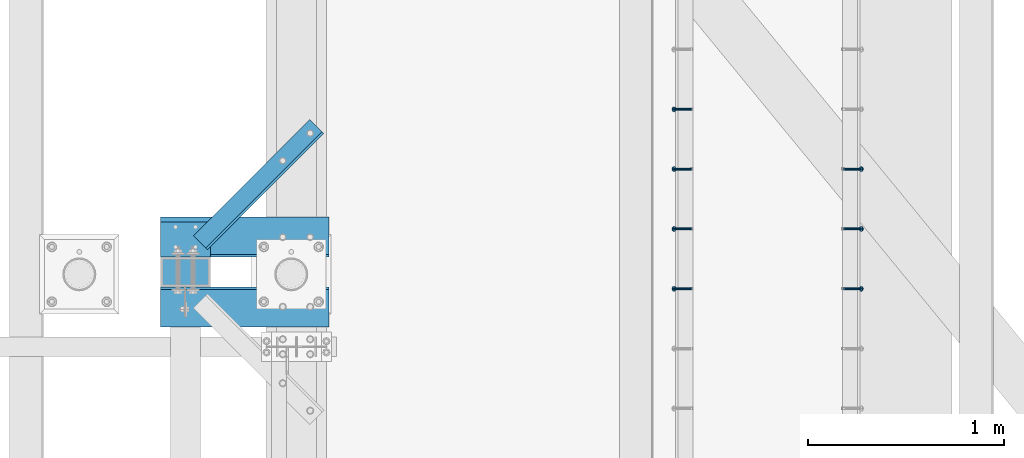
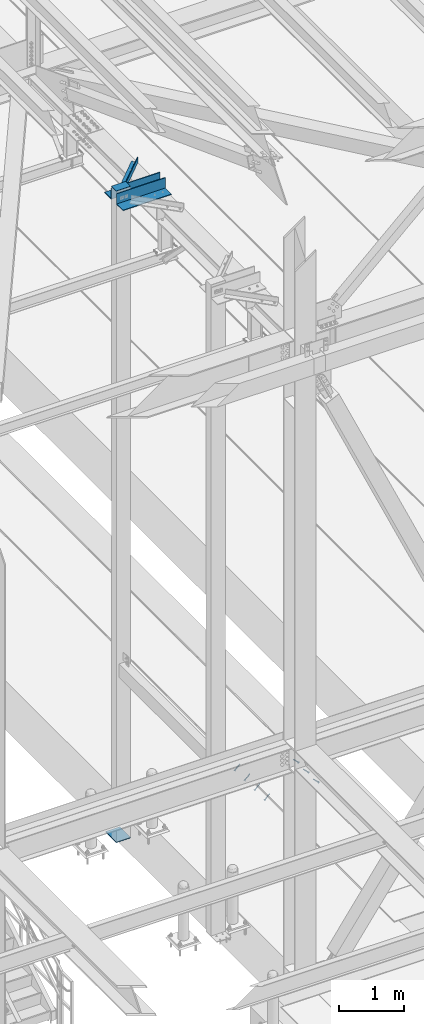
# One storey, part 2036 of 3843: 7 members, 5 beams, 6 elements without a shape of their own.
"""IFC2X3 building model written with IfcOpenShell, lengths in millimetres."""

from ifc_helpers import new_model, si_unit, frame, origin_with_axes, place, context, subcontext, project, spatial, faceted_brep, material, type_object, element, aggregate, save


model = new_model("IFC2X3")

# Units and contexts
model_context = context("Model", 3, precision=1e-05, world=origin_with_axes())
body_context = subcontext(model_context, "Body", "Model", "MODEL_VIEW")
ifc_project = project(units=[si_unit("LENGTHUNIT", "METRE", prefix="MILLI"), si_unit("AREAUNIT", "SQUARE_METRE"), si_unit("VOLUMEUNIT", "CUBIC_METRE"), si_unit("MASSUNIT", "GRAM", prefix="KILO"), si_unit("TIMEUNIT", "SECOND"), si_unit("PLANEANGLEUNIT", "RADIAN"), si_unit("SOLIDANGLEUNIT", "STERADIAN"), si_unit("THERMODYNAMICTEMPERATUREUNIT", "DEGREE_CELSIUS"), si_unit("LUMINOUSINTENSITYUNIT", "LUMEN")], contexts=[model_context])

# Site, building, storey
site_placement = place(None, origin_with_axes())
site = spatial("IfcSite", under=ifc_project, at=site_placement, CompositionType="ELEMENT")
building_placement = place(site_placement, origin_with_axes())
building = spatial("IfcBuilding", under=site, at=building_placement, Name="Undefined", CompositionType="ELEMENT")
storey_placement = place(building_placement, origin_with_axes())
storey = spatial("IfcBuildingStorey", under=building, at=storey_placement, Name="Undefined", CompositionType="ELEMENT", Elevation=0.0)

# Assembly, members
assembly_1_placement = place(storey_placement, origin_with_axes())
assembly_1 = element("IfcElementAssembly", 1, at=assembly_1_placement, inside=storey, Name="EMBED_ANGLE", AssemblyPlace="NOTDEFINED", PredefinedType="RIGID_FRAME")
ifc_material_1 = material(Name="STEEL/A108")
member_type = type_object("IfcMemberType", PredefinedType="NOTDEFINED")
member_1_placement = place(assembly_1_placement, frame((44851.3834999999, 30025.975189209, 30456.1875), z_axis=(0.0, 1.0, 0.0), x_axis=(0.707106781186548, 0.0, -0.707106781186548)))
member_1 = element("IfcMember", 2, at=member_1_placement, type_object=member_type, material=ifc_material_1, Name="HEADED STUD ANCHOR", context=body_context, shape_type="Brep", body=[
    faceted_brep([(7.27595761418343e-12, -3.18000006675175, 5.5), (0.0, -5.49999999998363, 3.1800000667572), (118.110000000976, -5.49999999999091, 3.1800000667572), (118.110000000983, -3.18000006675175, 5.5), (0.0, -6.3499999046162, 0.0), (118.110000000968, -6.34999990461256, 0.0), (0.0, -5.49999999998363, -3.1800000667572), (118.110000000976, -5.49999999999091, -3.1800000667572), (7.27595761418343e-12, -3.18000006675175, -5.5), (118.110000000983, -3.18000006675175, -5.5), (7.27595761418343e-12, -1.81898940354586e-12, -6.34999990463257), (118.110000000968, -1.81898940354586e-12, -6.34999990463257), (0.0, 3.18000006675175, -5.5), (118.110000000968, 3.18000006674811, -5.5), (7.27595761418343e-12, 5.49999999998363, -3.1800000667572), (118.110000000983, 5.49999999998363, -3.1800000667572), (7.27595761418343e-12, 6.3499999046162, 0.0), (118.110000000976, 6.34999990461256, 0.0), (7.27595761418343e-12, 5.49999999998363, 3.1800000667572), (118.110000000983, 5.49999999998363, 3.1800000667572), (0.0, 3.18000006675175, 5.5), (118.110000000968, 3.18000006674811, 5.5), (7.27595761418343e-12, -1.81898940354586e-12, 6.34999990463257), (118.110000000968, -1.81898940354586e-12, 6.34999990463257), (120.650000000991, -10.9899997710909, 6.34999990463257), (120.650000000998, -6.34000015257152, 10.9899997711182), (120.650000000991, -12.6999998092379, 0.0), (120.650000000991, -10.9899997710909, -6.34999990463257), (120.650000000998, -6.34000015257152, -10.9899997711182), (120.650000000991, -1.81898940354586e-12, -12.6899995803833), (120.650000000991, 6.34000015257152, -10.9899997711182), (120.650000000998, 10.9899997710909, -6.34999990463257), (120.650000000991, 12.6999998092342, 0.0), (120.650000000998, 10.9899997710909, 6.34999990463257), (120.650000000991, 6.34000015257152, 10.9899997711182), (120.650000000991, -1.81898940354586e-12, 12.6899995803833), (127.000000001048, -10.9899997710945, 6.34999990463257), (127.000000001048, -6.34000015257152, 10.9899997711182), (127.000000001048, -12.6999998092342, 0.0), (127.000000001048, -10.9899997710945, -6.34999990463257), (127.000000001048, -6.34000015257152, -10.9899997711182), (127.000000001048, 1.81898940354586e-12, -12.6899995803833), (127.000000001048, 6.34000015256788, -10.9899997711182), (127.000000001048, 10.9899997710909, -6.34999990463257), (127.000000001048, 12.6999998092379, 0.0), (127.000000001048, 10.9899997710909, 6.34999990463257), (127.000000001048, 6.34000015256788, 10.9899997711182), (127.000000001048, 1.81898940354586e-12, 12.6899995803833)], [[[0, 1, 2, 3]], [[1, 4, 5, 2]], [[4, 6, 7, 5]], [[6, 8, 9, 7]], [[8, 10, 11, 9]], [[10, 12, 13, 11]], [[12, 14, 15, 13]], [[14, 16, 17, 15]], [[16, 18, 19, 17]], [[18, 20, 21, 19]], [[20, 22, 23, 21]], [[22, 0, 3, 23]], [[22, 20, 18, 16, 14, 12, 10, 8, 6, 4, 1, 0]], [[3, 2, 24, 25]], [[2, 5, 26, 24]], [[5, 7, 27, 26]], [[7, 9, 28, 27]], [[9, 11, 29, 28]], [[11, 13, 30, 29]], [[13, 15, 31, 30]], [[15, 17, 32, 31]], [[17, 19, 33, 32]], [[19, 21, 34, 33]], [[21, 23, 35, 34]], [[23, 3, 25, 35]], [[25, 24, 36, 37]], [[24, 26, 38, 36]], [[26, 27, 39, 38]], [[27, 28, 40, 39]], [[28, 29, 41, 40]], [[29, 30, 42, 41]], [[30, 31, 43, 42]], [[31, 32, 44, 43]], [[32, 33, 45, 44]], [[33, 34, 46, 45]], [[34, 35, 47, 46]], [[35, 25, 37, 47]], [[38, 39, 40, 41, 42, 43, 44, 45, 46, 47, 37, 36]]]),
])
member_2_placement = place(assembly_1_placement, frame((44851.3834999999, 30330.775189209, 30456.1875), z_axis=(0.0, 1.0, 0.0), x_axis=(0.707106781186548, 0.0, -0.707106781186548)))
member_2 = element("IfcMember", 3, at=member_2_placement, type_object=member_type, material=ifc_material_1, Name="HEADED STUD ANCHOR", context=body_context, shape_type="Brep", body=[
    faceted_brep([(7.27595761418343e-12, -3.18000006675175, 5.5), (0.0, -5.49999999998363, 3.1800000667572), (118.110000000976, -5.49999999999091, 3.1800000667572), (118.110000000983, -3.18000006675175, 5.5), (0.0, -6.3499999046162, 0.0), (118.110000000968, -6.34999990461256, 0.0), (0.0, -5.49999999998363, -3.1800000667572), (118.110000000976, -5.49999999999091, -3.1800000667572), (7.27595761418343e-12, -3.18000006675175, -5.5), (118.110000000983, -3.18000006675175, -5.5), (7.27595761418343e-12, -1.81898940354586e-12, -6.34999990463257), (118.110000000968, -1.81898940354586e-12, -6.34999990463257), (0.0, 3.18000006675175, -5.5), (118.110000000968, 3.18000006674811, -5.5), (7.27595761418343e-12, 5.49999999998363, -3.1800000667572), (118.110000000983, 5.49999999998363, -3.1800000667572), (7.27595761418343e-12, 6.3499999046162, 0.0), (118.110000000976, 6.34999990461256, 0.0), (7.27595761418343e-12, 5.49999999998363, 3.1800000667572), (118.110000000983, 5.49999999998363, 3.1800000667572), (0.0, 3.18000006675175, 5.5), (118.110000000968, 3.18000006674811, 5.5), (7.27595761418343e-12, -1.81898940354586e-12, 6.34999990463257), (118.110000000968, -1.81898940354586e-12, 6.34999990463257), (120.650000000991, -10.9899997710909, 6.34999990463257), (120.650000000998, -6.34000015257152, 10.9899997711182), (120.650000000991, -12.6999998092379, 0.0), (120.650000000991, -10.9899997710909, -6.34999990463257), (120.650000000998, -6.34000015257152, -10.9899997711182), (120.650000000991, -1.81898940354586e-12, -12.6899995803833), (120.650000000991, 6.34000015257152, -10.9899997711182), (120.650000000998, 10.9899997710909, -6.34999990463257), (120.650000000991, 12.6999998092342, 0.0), (120.650000000998, 10.9899997710909, 6.34999990463257), (120.650000000991, 6.34000015257152, 10.9899997711182), (120.650000000991, -1.81898940354586e-12, 12.6899995803833), (127.000000001048, -10.9899997710945, 6.34999990463257), (127.000000001048, -6.34000015257152, 10.9899997711182), (127.000000001048, -12.6999998092342, 0.0), (127.000000001048, -10.9899997710945, -6.34999990463257), (127.000000001048, -6.34000015257152, -10.9899997711182), (127.000000001048, 1.81898940354586e-12, -12.6899995803833), (127.000000001048, 6.34000015256788, -10.9899997711182), (127.000000001048, 10.9899997710909, -6.34999990463257), (127.000000001048, 12.6999998092379, 0.0), (127.000000001048, 10.9899997710909, 6.34999990463257), (127.000000001048, 6.34000015256788, 10.9899997711182), (127.000000001048, 1.81898940354586e-12, 12.6899995803833)], [[[0, 1, 2, 3]], [[1, 4, 5, 2]], [[4, 6, 7, 5]], [[6, 8, 9, 7]], [[8, 10, 11, 9]], [[10, 12, 13, 11]], [[12, 14, 15, 13]], [[14, 16, 17, 15]], [[16, 18, 19, 17]], [[18, 20, 21, 19]], [[20, 22, 23, 21]], [[22, 0, 3, 23]], [[22, 20, 18, 16, 14, 12, 10, 8, 6, 4, 1, 0]], [[3, 2, 24, 25]], [[2, 5, 26, 24]], [[5, 7, 27, 26]], [[7, 9, 28, 27]], [[9, 11, 29, 28]], [[11, 13, 30, 29]], [[13, 15, 31, 30]], [[15, 17, 32, 31]], [[17, 19, 33, 32]], [[19, 21, 34, 33]], [[21, 23, 35, 34]], [[23, 3, 25, 35]], [[25, 24, 36, 37]], [[24, 26, 38, 36]], [[26, 27, 39, 38]], [[27, 28, 40, 39]], [[28, 29, 41, 40]], [[29, 30, 42, 41]], [[30, 31, 43, 42]], [[31, 32, 44, 43]], [[32, 33, 45, 44]], [[33, 34, 46, 45]], [[34, 35, 47, 46]], [[35, 25, 37, 47]], [[38, 39, 40, 41, 42, 43, 44, 45, 46, 47, 37, 36]]]),
])
member_3_placement = place(assembly_1_placement, frame((44851.3834999999, 30635.575189209, 30456.1875), z_axis=(0.0, 1.0, 0.0), x_axis=(0.707106781186548, 0.0, -0.707106781186548)))
member_3 = element("IfcMember", 4, at=member_3_placement, type_object=member_type, material=ifc_material_1, Name="HEADED STUD ANCHOR", context=body_context, shape_type="Brep", body=[
    faceted_brep([(7.27595761418343e-12, -3.18000006675175, 5.5), (0.0, -5.49999999998363, 3.1800000667572), (118.110000000976, -5.49999999999091, 3.1800000667572), (118.110000000983, -3.18000006675175, 5.5), (0.0, -6.3499999046162, 0.0), (118.110000000968, -6.34999990461256, 0.0), (0.0, -5.49999999998363, -3.1800000667572), (118.110000000976, -5.49999999999091, -3.1800000667572), (7.27595761418343e-12, -3.18000006675175, -5.5), (118.110000000983, -3.18000006675175, -5.5), (7.27595761418343e-12, -1.81898940354586e-12, -6.34999990463257), (118.110000000968, -1.81898940354586e-12, -6.34999990463257), (0.0, 3.18000006675175, -5.5), (118.110000000968, 3.18000006674811, -5.5), (7.27595761418343e-12, 5.49999999998363, -3.1800000667572), (118.110000000983, 5.49999999998363, -3.1800000667572), (7.27595761418343e-12, 6.3499999046162, 0.0), (118.110000000976, 6.34999990461256, 0.0), (7.27595761418343e-12, 5.49999999998363, 3.1800000667572), (118.110000000983, 5.49999999998363, 3.1800000667572), (0.0, 3.18000006675175, 5.5), (118.110000000968, 3.18000006674811, 5.5), (7.27595761418343e-12, -1.81898940354586e-12, 6.34999990463257), (118.110000000968, -1.81898940354586e-12, 6.34999990463257), (120.650000000991, -10.9899997710909, 6.34999990463257), (120.650000000998, -6.34000015257152, 10.9899997711182), (120.650000000991, -12.6999998092379, 0.0), (120.650000000991, -10.9899997710909, -6.34999990463257), (120.650000000998, -6.34000015257152, -10.9899997711182), (120.650000000991, -1.81898940354586e-12, -12.6899995803833), (120.650000000991, 6.34000015257152, -10.9899997711182), (120.650000000998, 10.9899997710909, -6.34999990463257), (120.650000000991, 12.6999998092342, 0.0), (120.650000000998, 10.9899997710909, 6.34999990463257), (120.650000000991, 6.34000015257152, 10.9899997711182), (120.650000000991, -1.81898940354586e-12, 12.6899995803833), (127.000000001048, -10.9899997710945, 6.34999990463257), (127.000000001048, -6.34000015257152, 10.9899997711182), (127.000000001048, -12.6999998092342, 0.0), (127.000000001048, -10.9899997710945, -6.34999990463257), (127.000000001048, -6.34000015257152, -10.9899997711182), (127.000000001048, 1.81898940354586e-12, -12.6899995803833), (127.000000001048, 6.34000015256788, -10.9899997711182), (127.000000001048, 10.9899997710909, -6.34999990463257), (127.000000001048, 12.6999998092379, 0.0), (127.000000001048, 10.9899997710909, 6.34999990463257), (127.000000001048, 6.34000015256788, 10.9899997711182), (127.000000001048, 1.81898940354586e-12, 12.6899995803833)], [[[0, 1, 2, 3]], [[1, 4, 5, 2]], [[4, 6, 7, 5]], [[6, 8, 9, 7]], [[8, 10, 11, 9]], [[10, 12, 13, 11]], [[12, 14, 15, 13]], [[14, 16, 17, 15]], [[16, 18, 19, 17]], [[18, 20, 21, 19]], [[20, 22, 23, 21]], [[22, 0, 3, 23]], [[22, 20, 18, 16, 14, 12, 10, 8, 6, 4, 1, 0]], [[3, 2, 24, 25]], [[2, 5, 26, 24]], [[5, 7, 27, 26]], [[7, 9, 28, 27]], [[9, 11, 29, 28]], [[11, 13, 30, 29]], [[13, 15, 31, 30]], [[15, 17, 32, 31]], [[17, 19, 33, 32]], [[19, 21, 34, 33]], [[21, 23, 35, 34]], [[23, 3, 25, 35]], [[25, 24, 36, 37]], [[24, 26, 38, 36]], [[26, 27, 39, 38]], [[27, 28, 40, 39]], [[28, 29, 41, 40]], [[29, 30, 42, 41]], [[30, 31, 43, 42]], [[31, 32, 44, 43]], [[32, 33, 45, 44]], [[33, 34, 46, 45]], [[34, 35, 47, 46]], [[35, 25, 37, 47]], [[38, 39, 40, 41, 42, 43, 44, 45, 46, 47, 37, 36]]]),
])
aggregate(assembly_1, [member_1, member_2, member_3])

assembly_2_placement = place(storey_placement, origin_with_axes())
assembly_2 = element("IfcElementAssembly", 5, at=assembly_2_placement, inside=storey, Name="EMBED_ANGLE", AssemblyPlace="NOTDEFINED", PredefinedType="RIGID_FRAME")
member_4_placement = place(assembly_2_placement, frame((44073.5085000003, 30025.975189209, 30456.1874999998), z_axis=(0.0, -1.0, 0.0), x_axis=(-0.707106781186548, 0.0, -0.707106781186548)))
member_4 = element("IfcMember", 6, at=member_4_placement, type_object=member_type, material=ifc_material_1, Name="HEADED STUD ANCHOR", context=body_context, shape_type="Brep", body=[
    faceted_brep([(7.27595761418343e-12, -3.18000006675175, 5.5), (0.0, -5.49999999998363, 3.1800000667572), (118.110000000976, -5.49999999999091, 3.1800000667572), (118.110000000983, -3.18000006675175, 5.5), (0.0, -6.3499999046162, 0.0), (118.110000000968, -6.34999990461256, 0.0), (0.0, -5.49999999998363, -3.1800000667572), (118.110000000976, -5.49999999999091, -3.1800000667572), (7.27595761418343e-12, -3.18000006675175, -5.5), (118.110000000983, -3.18000006675175, -5.5), (7.27595761418343e-12, -1.81898940354586e-12, -6.34999990463257), (118.110000000968, -1.81898940354586e-12, -6.34999990463257), (0.0, 3.18000006675175, -5.5), (118.110000000968, 3.18000006674811, -5.5), (7.27595761418343e-12, 5.49999999998363, -3.1800000667572), (118.110000000983, 5.49999999998363, -3.1800000667572), (7.27595761418343e-12, 6.3499999046162, 0.0), (118.110000000976, 6.34999990461256, 0.0), (7.27595761418343e-12, 5.49999999998363, 3.1800000667572), (118.110000000983, 5.49999999998363, 3.1800000667572), (0.0, 3.18000006675175, 5.5), (118.110000000968, 3.18000006674811, 5.5), (7.27595761418343e-12, -1.81898940354586e-12, 6.34999990463257), (118.110000000968, -1.81898940354586e-12, 6.34999990463257), (120.650000000991, -10.9899997710909, 6.34999990463257), (120.650000000998, -6.34000015257152, 10.9899997711182), (120.650000000991, -12.6999998092379, 0.0), (120.650000000991, -10.9899997710909, -6.34999990463257), (120.650000000998, -6.34000015257152, -10.9899997711182), (120.650000000991, -1.81898940354586e-12, -12.6899995803833), (120.650000000991, 6.34000015257152, -10.9899997711182), (120.650000000998, 10.9899997710909, -6.34999990463257), (120.650000000991, 12.6999998092342, 0.0), (120.650000000998, 10.9899997710909, 6.34999990463257), (120.650000000991, 6.34000015257152, 10.9899997711182), (120.650000000991, -1.81898940354586e-12, 12.6899995803833), (127.000000001048, -10.9899997710945, 6.34999990463257), (127.000000001048, -6.34000015257152, 10.9899997711182), (127.000000001048, -12.6999998092342, 0.0), (127.000000001048, -10.9899997710945, -6.34999990463257), (127.000000001048, -6.34000015257152, -10.9899997711182), (127.000000001048, 1.81898940354586e-12, -12.6899995803833), (127.000000001048, 6.34000015256788, -10.9899997711182), (127.000000001048, 10.9899997710909, -6.34999990463257), (127.000000001048, 12.6999998092379, 0.0), (127.000000001048, 10.9899997710909, 6.34999990463257), (127.000000001048, 6.34000015256788, 10.9899997711182), (127.000000001048, 1.81898940354586e-12, 12.6899995803833)], [[[0, 1, 2, 3]], [[1, 4, 5, 2]], [[4, 6, 7, 5]], [[6, 8, 9, 7]], [[8, 10, 11, 9]], [[10, 12, 13, 11]], [[12, 14, 15, 13]], [[14, 16, 17, 15]], [[16, 18, 19, 17]], [[18, 20, 21, 19]], [[20, 22, 23, 21]], [[22, 0, 3, 23]], [[22, 20, 18, 16, 14, 12, 10, 8, 6, 4, 1, 0]], [[3, 2, 24, 25]], [[2, 5, 26, 24]], [[5, 7, 27, 26]], [[7, 9, 28, 27]], [[9, 11, 29, 28]], [[11, 13, 30, 29]], [[13, 15, 31, 30]], [[15, 17, 32, 31]], [[17, 19, 33, 32]], [[19, 21, 34, 33]], [[21, 23, 35, 34]], [[23, 3, 25, 35]], [[25, 24, 36, 37]], [[24, 26, 38, 36]], [[26, 27, 39, 38]], [[27, 28, 40, 39]], [[28, 29, 41, 40]], [[29, 30, 42, 41]], [[30, 31, 43, 42]], [[31, 32, 44, 43]], [[32, 33, 45, 44]], [[33, 34, 46, 45]], [[34, 35, 47, 46]], [[35, 25, 37, 47]], [[38, 39, 40, 41, 42, 43, 44, 45, 46, 47, 37, 36]]]),
])
member_5_placement = place(assembly_2_placement, frame((44073.5085000003, 30330.775189209, 30456.1874999998), z_axis=(0.0, -1.0, 0.0), x_axis=(-0.707106781186548, 0.0, -0.707106781186548)))
member_5 = element("IfcMember", 7, at=member_5_placement, type_object=member_type, material=ifc_material_1, Name="HEADED STUD ANCHOR", context=body_context, shape_type="Brep", body=[
    faceted_brep([(7.27595761418343e-12, -3.18000006675175, 5.5), (0.0, -5.49999999998363, 3.1800000667572), (118.110000000976, -5.49999999999091, 3.1800000667572), (118.110000000983, -3.18000006675175, 5.5), (0.0, -6.3499999046162, 0.0), (118.110000000968, -6.34999990461256, 0.0), (0.0, -5.49999999998363, -3.1800000667572), (118.110000000976, -5.49999999999091, -3.1800000667572), (7.27595761418343e-12, -3.18000006675175, -5.5), (118.110000000983, -3.18000006675175, -5.5), (7.27595761418343e-12, -1.81898940354586e-12, -6.34999990463257), (118.110000000968, -1.81898940354586e-12, -6.34999990463257), (0.0, 3.18000006675175, -5.5), (118.110000000968, 3.18000006674811, -5.5), (7.27595761418343e-12, 5.49999999998363, -3.1800000667572), (118.110000000983, 5.49999999998363, -3.1800000667572), (7.27595761418343e-12, 6.3499999046162, 0.0), (118.110000000976, 6.34999990461256, 0.0), (7.27595761418343e-12, 5.49999999998363, 3.1800000667572), (118.110000000983, 5.49999999998363, 3.1800000667572), (0.0, 3.18000006675175, 5.5), (118.110000000968, 3.18000006674811, 5.5), (7.27595761418343e-12, -1.81898940354586e-12, 6.34999990463257), (118.110000000968, -1.81898940354586e-12, 6.34999990463257), (120.650000000991, -10.9899997710909, 6.34999990463257), (120.650000000998, -6.34000015257152, 10.9899997711182), (120.650000000991, -12.6999998092379, 0.0), (120.650000000991, -10.9899997710909, -6.34999990463257), (120.650000000998, -6.34000015257152, -10.9899997711182), (120.650000000991, -1.81898940354586e-12, -12.6899995803833), (120.650000000991, 6.34000015257152, -10.9899997711182), (120.650000000998, 10.9899997710909, -6.34999990463257), (120.650000000991, 12.6999998092342, 0.0), (120.650000000998, 10.9899997710909, 6.34999990463257), (120.650000000991, 6.34000015257152, 10.9899997711182), (120.650000000991, -1.81898940354586e-12, 12.6899995803833), (127.000000001048, -10.9899997710945, 6.34999990463257), (127.000000001048, -6.34000015257152, 10.9899997711182), (127.000000001048, -12.6999998092342, 0.0), (127.000000001048, -10.9899997710945, -6.34999990463257), (127.000000001048, -6.34000015257152, -10.9899997711182), (127.000000001048, 1.81898940354586e-12, -12.6899995803833), (127.000000001048, 6.34000015256788, -10.9899997711182), (127.000000001048, 10.9899997710909, -6.34999990463257), (127.000000001048, 12.6999998092379, 0.0), (127.000000001048, 10.9899997710909, 6.34999990463257), (127.000000001048, 6.34000015256788, 10.9899997711182), (127.000000001048, 1.81898940354586e-12, 12.6899995803833)], [[[0, 1, 2, 3]], [[1, 4, 5, 2]], [[4, 6, 7, 5]], [[6, 8, 9, 7]], [[8, 10, 11, 9]], [[10, 12, 13, 11]], [[12, 14, 15, 13]], [[14, 16, 17, 15]], [[16, 18, 19, 17]], [[18, 20, 21, 19]], [[20, 22, 23, 21]], [[22, 0, 3, 23]], [[22, 20, 18, 16, 14, 12, 10, 8, 6, 4, 1, 0]], [[3, 2, 24, 25]], [[2, 5, 26, 24]], [[5, 7, 27, 26]], [[7, 9, 28, 27]], [[9, 11, 29, 28]], [[11, 13, 30, 29]], [[13, 15, 31, 30]], [[15, 17, 32, 31]], [[17, 19, 33, 32]], [[19, 21, 34, 33]], [[21, 23, 35, 34]], [[23, 3, 25, 35]], [[25, 24, 36, 37]], [[24, 26, 38, 36]], [[26, 27, 39, 38]], [[27, 28, 40, 39]], [[28, 29, 41, 40]], [[29, 30, 42, 41]], [[30, 31, 43, 42]], [[31, 32, 44, 43]], [[32, 33, 45, 44]], [[33, 34, 46, 45]], [[34, 35, 47, 46]], [[35, 25, 37, 47]], [[38, 39, 40, 41, 42, 43, 44, 45, 46, 47, 37, 36]]]),
])
member_6_placement = place(assembly_2_placement, frame((44073.5085000003, 30635.575189209, 30456.1874999998), z_axis=(0.0, -1.0, 0.0), x_axis=(-0.707106781186548, 0.0, -0.707106781186548)))
member_6 = element("IfcMember", 8, at=member_6_placement, type_object=member_type, material=ifc_material_1, Name="HEADED STUD ANCHOR", context=body_context, shape_type="Brep", body=[
    faceted_brep([(7.27595761418343e-12, -3.18000006675175, 5.5), (0.0, -5.49999999998363, 3.1800000667572), (118.110000000976, -5.49999999999091, 3.1800000667572), (118.110000000983, -3.18000006675175, 5.5), (0.0, -6.3499999046162, 0.0), (118.110000000968, -6.34999990461256, 0.0), (0.0, -5.49999999998363, -3.1800000667572), (118.110000000976, -5.49999999999091, -3.1800000667572), (7.27595761418343e-12, -3.18000006675175, -5.5), (118.110000000983, -3.18000006675175, -5.5), (7.27595761418343e-12, -1.81898940354586e-12, -6.34999990463257), (118.110000000968, -1.81898940354586e-12, -6.34999990463257), (0.0, 3.18000006675175, -5.5), (118.110000000968, 3.18000006674811, -5.5), (7.27595761418343e-12, 5.49999999998363, -3.1800000667572), (118.110000000983, 5.49999999998363, -3.1800000667572), (7.27595761418343e-12, 6.3499999046162, 0.0), (118.110000000976, 6.34999990461256, 0.0), (7.27595761418343e-12, 5.49999999998363, 3.1800000667572), (118.110000000983, 5.49999999998363, 3.1800000667572), (0.0, 3.18000006675175, 5.5), (118.110000000968, 3.18000006674811, 5.5), (7.27595761418343e-12, -1.81898940354586e-12, 6.34999990463257), (118.110000000968, -1.81898940354586e-12, 6.34999990463257), (120.650000000991, -10.9899997710909, 6.34999990463257), (120.650000000998, -6.34000015257152, 10.9899997711182), (120.650000000991, -12.6999998092379, 0.0), (120.650000000991, -10.9899997710909, -6.34999990463257), (120.650000000998, -6.34000015257152, -10.9899997711182), (120.650000000991, -1.81898940354586e-12, -12.6899995803833), (120.650000000991, 6.34000015257152, -10.9899997711182), (120.650000000998, 10.9899997710909, -6.34999990463257), (120.650000000991, 12.6999998092342, 0.0), (120.650000000998, 10.9899997710909, 6.34999990463257), (120.650000000991, 6.34000015257152, 10.9899997711182), (120.650000000991, -1.81898940354586e-12, 12.6899995803833), (127.000000001048, -10.9899997710945, 6.34999990463257), (127.000000001048, -6.34000015257152, 10.9899997711182), (127.000000001048, -12.6999998092342, 0.0), (127.000000001048, -10.9899997710945, -6.34999990463257), (127.000000001048, -6.34000015257152, -10.9899997711182), (127.000000001048, 1.81898940354586e-12, -12.6899995803833), (127.000000001048, 6.34000015256788, -10.9899997711182), (127.000000001048, 10.9899997710909, -6.34999990463257), (127.000000001048, 12.6999998092379, 0.0), (127.000000001048, 10.9899997710909, 6.34999990463257), (127.000000001048, 6.34000015256788, 10.9899997711182), (127.000000001048, 1.81898940354586e-12, 12.6899995803833)], [[[0, 1, 2, 3]], [[1, 4, 5, 2]], [[4, 6, 7, 5]], [[6, 8, 9, 7]], [[8, 10, 11, 9]], [[10, 12, 13, 11]], [[12, 14, 15, 13]], [[14, 16, 17, 15]], [[16, 18, 19, 17]], [[18, 20, 21, 19]], [[20, 22, 23, 21]], [[22, 0, 3, 23]], [[22, 20, 18, 16, 14, 12, 10, 8, 6, 4, 1, 0]], [[3, 2, 24, 25]], [[2, 5, 26, 24]], [[5, 7, 27, 26]], [[7, 9, 28, 27]], [[9, 11, 29, 28]], [[11, 13, 30, 29]], [[13, 15, 31, 30]], [[15, 17, 32, 31]], [[17, 19, 33, 32]], [[19, 21, 34, 33]], [[21, 23, 35, 34]], [[23, 3, 25, 35]], [[25, 24, 36, 37]], [[24, 26, 38, 36]], [[26, 27, 39, 38]], [[27, 28, 40, 39]], [[28, 29, 41, 40]], [[29, 30, 42, 41]], [[30, 31, 43, 42]], [[31, 32, 44, 43]], [[32, 33, 45, 44]], [[33, 34, 46, 45]], [[34, 35, 47, 46]], [[35, 25, 37, 47]], [[38, 39, 40, 41, 42, 43, 44, 45, 46, 47, 37, 36]]]),
])
member_7_placement = place(assembly_2_placement, frame((44073.5085000003, 30940.375189209, 30456.1874999998), z_axis=(0.0, -1.0, 0.0), x_axis=(-0.707106781186548, 0.0, -0.707106781186548)))
member_7 = element("IfcMember", 9, at=member_7_placement, type_object=member_type, material=ifc_material_1, Name="HEADED STUD ANCHOR", context=body_context, shape_type="Brep", body=[
    faceted_brep([(7.27595761418343e-12, -3.18000006675175, 5.5), (0.0, -5.49999999998363, 3.1800000667572), (118.110000000976, -5.49999999999091, 3.1800000667572), (118.110000000983, -3.18000006675175, 5.5), (0.0, -6.3499999046162, 0.0), (118.110000000968, -6.34999990461256, 0.0), (0.0, -5.49999999998363, -3.1800000667572), (118.110000000976, -5.49999999999091, -3.1800000667572), (7.27595761418343e-12, -3.18000006675175, -5.5), (118.110000000983, -3.18000006675175, -5.5), (7.27595761418343e-12, -1.81898940354586e-12, -6.34999990463257), (118.110000000968, -1.81898940354586e-12, -6.34999990463257), (0.0, 3.18000006675175, -5.5), (118.110000000968, 3.18000006674811, -5.5), (7.27595761418343e-12, 5.49999999998363, -3.1800000667572), (118.110000000983, 5.49999999998363, -3.1800000667572), (7.27595761418343e-12, 6.3499999046162, 0.0), (118.110000000976, 6.34999990461256, 0.0), (7.27595761418343e-12, 5.49999999998363, 3.1800000667572), (118.110000000983, 5.49999999998363, 3.1800000667572), (0.0, 3.18000006675175, 5.5), (118.110000000968, 3.18000006674811, 5.5), (7.27595761418343e-12, -1.81898940354586e-12, 6.34999990463257), (118.110000000968, -1.81898940354586e-12, 6.34999990463257), (120.650000000991, -10.9899997710909, 6.34999990463257), (120.650000000998, -6.34000015257152, 10.9899997711182), (120.650000000991, -12.6999998092379, 0.0), (120.650000000991, -10.9899997710909, -6.34999990463257), (120.650000000998, -6.34000015257152, -10.9899997711182), (120.650000000991, -1.81898940354586e-12, -12.6899995803833), (120.650000000991, 6.34000015257152, -10.9899997711182), (120.650000000998, 10.9899997710909, -6.34999990463257), (120.650000000991, 12.6999998092342, 0.0), (120.650000000998, 10.9899997710909, 6.34999990463257), (120.650000000991, 6.34000015257152, 10.9899997711182), (120.650000000991, -1.81898940354586e-12, 12.6899995803833), (127.000000001048, -10.9899997710945, 6.34999990463257), (127.000000001048, -6.34000015257152, 10.9899997711182), (127.000000001048, -12.6999998092342, 0.0), (127.000000001048, -10.9899997710945, -6.34999990463257), (127.000000001048, -6.34000015257152, -10.9899997711182), (127.000000001048, 1.81898940354586e-12, -12.6899995803833), (127.000000001048, 6.34000015256788, -10.9899997711182), (127.000000001048, 10.9899997710909, -6.34999990463257), (127.000000001048, 12.6999998092379, 0.0), (127.000000001048, 10.9899997710909, 6.34999990463257), (127.000000001048, 6.34000015256788, 10.9899997711182), (127.000000001048, 1.81898940354586e-12, 12.6899995803833)], [[[0, 1, 2, 3]], [[1, 4, 5, 2]], [[4, 6, 7, 5]], [[6, 8, 9, 7]], [[8, 10, 11, 9]], [[10, 12, 13, 11]], [[12, 14, 15, 13]], [[14, 16, 17, 15]], [[16, 18, 19, 17]], [[18, 20, 21, 19]], [[20, 22, 23, 21]], [[22, 0, 3, 23]], [[22, 20, 18, 16, 14, 12, 10, 8, 6, 4, 1, 0]], [[3, 2, 24, 25]], [[2, 5, 26, 24]], [[5, 7, 27, 26]], [[7, 9, 28, 27]], [[9, 11, 29, 28]], [[11, 13, 30, 29]], [[13, 15, 31, 30]], [[15, 17, 32, 31]], [[17, 19, 33, 32]], [[19, 21, 34, 33]], [[21, 23, 35, 34]], [[23, 3, 25, 35]], [[25, 24, 36, 37]], [[24, 26, 38, 36]], [[26, 27, 39, 38]], [[27, 28, 40, 39]], [[28, 29, 41, 40]], [[29, 30, 42, 41]], [[30, 31, 43, 42]], [[31, 32, 44, 43]], [[32, 33, 45, 44]], [[33, 34, 46, 45]], [[34, 35, 47, 46]], [[35, 25, 37, 47]], [[38, 39, 40, 41, 42, 43, 44, 45, 46, 47, 37, 36]]]),
])
aggregate(assembly_2, [member_4, member_5, member_6, member_7])

# Assembly, beam
assembly_3_placement = place(storey_placement, origin_with_axes())
assembly_3 = element("IfcElementAssembly", 10, at=assembly_3_placement, inside=storey, Name="ANGLE", AssemblyPlace="NOTDEFINED", PredefinedType="RIGID_FRAME")
ifc_material_2 = material(Name="STEEL/A572-50")
beam_type_1 = type_object("IfcBeamType", Name="L4X4X1/2", PredefinedType="NOTDEFINED")
beam_1_placement = place(assembly_3_placement, frame((42166.1469039905, 30852.4389529592, 42474.3146705007), z_axis=(0.0, 0.0, 1.0), x_axis=(-0.707106781186549, -0.707106781186546, 0.0)))
beam_1 = element("IfcBeam", 11, at=beam_1_placement, type_object=beam_type_1, material=ifc_material_2, Name="ANGLE", ObjectType="L4X4X1/2", context=body_context, shape_type="Brep", body=[
    faceted_brep([(0.0, 50.8000000000029, -50.8000000000029), (0.0, 50.8000000000029, 50.8000000000029), (838.199999993831, 50.7999999998719, 50.8000000000029), (838.199999993831, 50.7999999998719, -50.8000000000029), (0.0, 38.0999999999985, 50.8000000000029), (838.199999993823, 38.099999999904, 50.8000000000029), (0.0, 38.0999999999985, -38.0999999999985), (838.199999993823, 38.099999999904, -38.0999999999985), (0.0, -50.8000000000029, -38.1000000000058), (838.199999993823, -50.7999999998865, -38.0999999999985), (0.0, -50.8000000000029, -50.8000000000029), (838.199999993823, -50.7999999998865, -50.8000000000029)], [[[0, 1, 2, 3]], [[1, 4, 5, 2]], [[4, 6, 7, 5]], [[6, 8, 9, 7]], [[8, 10, 11, 9]], [[10, 0, 3, 11]], [[5, 7, 9, 11, 3, 2]], [[10, 8, 6, 4, 1, 0]]]),
])
aggregate(assembly_3, [beam_1])

assembly_4_placement = place(storey_placement, origin_with_axes())
assembly_4 = element("IfcElementAssembly", 12, at=assembly_4_placement, inside=storey, Name="POST", AssemblyPlace="NOTDEFINED", PredefinedType="RIGID_FRAME")
beam_type_2 = type_object("IfcBeamType", PredefinedType="NOTDEFINED")
beam_2_placement = place(assembly_4_placement, frame((41624.25, 30111.7, 42656.125), z_axis=(0.0, 1.0, 0.0), x_axis=(-1.0, 0.0, 0.0)))
beam_2 = element("IfcBeam", 13, at=beam_2_placement, type_object=beam_type_2, material=ifc_material_2, Name="PLATE", context=body_context, shape_type="Brep", body=[
    faceted_brep([(0.0, 3.17500000000291, -76.2000000000007), (0.0, 3.17499999999927, 76.1999969482422), (254.0, 3.17500000000291, 76.2000000000007), (254.0, 3.17500000000291, -76.2000000000007), (0.0, -3.17499999999927, 76.1999969482422), (254.0, -3.17500000000291, 76.2000000000007), (0.0, -3.17500000000291, -76.2000000000007), (254.0, -3.17500000000291, -76.2000000000007)], [[[0, 1, 2, 3]], [[1, 4, 5, 2]], [[4, 6, 7, 5]], [[6, 0, 3, 7]], [[5, 7, 3, 2]], [[6, 4, 1, 0]]]),
])

assembly_5_placement = place(storey_placement, origin_with_axes())
assembly_5 = element("IfcElementAssembly", 14, at=assembly_5_placement, inside=storey, Name="ANGLE", AssemblyPlace="NOTDEFINED", PredefinedType="RIGID_FRAME")
beam_type_3 = type_object("IfcBeamType", Name="L8X8X1/2", PredefinedType="NOTDEFINED")
beam_3_placement = place(assembly_5_placement, frame((41370.25, 29933.9, 42512.4146705007), z_axis=(0.0, 0.0, 1.0), x_axis=(1.0, 0.0, 0.0)))
beam_3 = element("IfcBeam", 15, at=beam_3_placement, type_object=beam_type_3, material=ifc_material_2, Name="ANGLE", ObjectType="L8X8X1/2", context=body_context, shape_type="Brep", body=[
    faceted_brep([(2.18278728425503e-10, 101.600000000345, -101.600000000006), (2.18278728425503e-10, 101.600000000345, 101.600000000006), (858.837500000009, 101.599999999999, 101.599999999999), (858.837500000009, 101.599999999999, -101.599999999999), (0.0, 88.9000000000015, 101.599999999999), (858.837500000009, 88.9000000000015, 101.599999999999), (0.0, 88.9000000000015, -88.9000000000015), (858.837500000009, 88.9000000000015, -88.9000000000015), (0.0, -101.599999999999, -88.9000000000015), (858.837500000009, -101.599999999999, -88.9000000000015), (-2.25554686039686e-10, -101.600000000329, -101.600000000006), (858.837500000009, -101.599999999999, -101.599999999999)], [[[0, 1, 2, 3]], [[1, 4, 5, 2]], [[4, 6, 7, 5]], [[6, 8, 9, 7]], [[8, 10, 11, 9]], [[10, 0, 3, 11]], [[5, 7, 9, 11, 3, 2]], [[10, 8, 6, 4, 1, 0]]]),
])
aggregate(assembly_5, [beam_3])

assembly_6_placement = place(storey_placement, origin_with_axes())
assembly_6 = element("IfcElementAssembly", 16, at=assembly_6_placement, inside=storey, Name="ANGLE", AssemblyPlace="NOTDEFINED", PredefinedType="RIGID_FRAME")
beam_4_placement = place(assembly_6_placement, frame((42229.0875, 30289.5, 42512.4146705007), z_axis=(0.0, 0.0, 1.0), x_axis=(-1.0, 0.0, 0.0)))
beam_4 = element("IfcBeam", 17, at=beam_4_placement, type_object=beam_type_3, material=ifc_material_2, Name="ANGLE", ObjectType="L8X8X1/2", context=body_context, shape_type="Brep", body=[
    faceted_brep([(2.18278728425503e-10, 101.600000000345, -101.600000000006), (2.18278728425503e-10, 101.600000000345, 101.600000000006), (858.837500000009, 101.599999999999, 101.599999999999), (858.837500000009, 101.599999999999, -101.599999999999), (0.0, 88.9000000000015, 101.599999999999), (858.837500000009, 88.9000000000015, 101.599999999999), (0.0, 88.9000000000015, -88.9000000000015), (858.837500000009, 88.9000000000015, -88.9000000000015), (0.0, -101.599999999999, -88.9000000000015), (858.837500000009, -101.599999999999, -88.9000000000015), (-2.25554686039686e-10, -101.600000000329, -101.600000000006), (858.837500000009, -101.599999999999, -101.599999999999)], [[[0, 1, 2, 3]], [[1, 4, 5, 2]], [[4, 6, 7, 5]], [[6, 8, 9, 7]], [[8, 10, 11, 9]], [[10, 0, 3, 11]], [[5, 7, 9, 11, 3, 2]], [[10, 8, 6, 4, 1, 0]]]),
])
aggregate(assembly_6, [beam_4])

# Beam
beam_type_4 = type_object("IfcBeamType", PredefinedType="NOTDEFINED")
beam_5_placement = place(assembly_4_placement, frame((41624.25, 30200.6, 30486.35), z_axis=(0.0, -1.0, 0.0), x_axis=(-1.0, 0.0, 0.0)))
beam_5 = element("IfcBeam", 18, at=beam_5_placement, type_object=beam_type_4, material=ifc_material_2, context=body_context, shape_type="Brep", body=[
    faceted_brep([(-4.07453626394272e-10, 6.34999999999854, -165.099999999366), (3.92901711165905e-10, 6.34999999999854, 165.099999999351), (254.0, 6.34999999999854, 165.099999999999), (254.0, 6.34999999999854, -165.099999999999), (3.92901711165905e-10, -6.34999999999854, 165.099999999351), (254.0, -6.34999999999854, 165.099999999999), (-4.07453626394272e-10, -6.34999999999854, -165.099999999366), (254.0, -6.34999999999854, -165.099999999999)], [[[0, 1, 2, 3]], [[1, 4, 5, 2]], [[4, 6, 7, 5]], [[6, 0, 3, 7]], [[5, 7, 3, 2]], [[6, 4, 1, 0]]]),
])

aggregate(assembly_4, [beam_2, beam_5])

save(model, "model.ifc")
